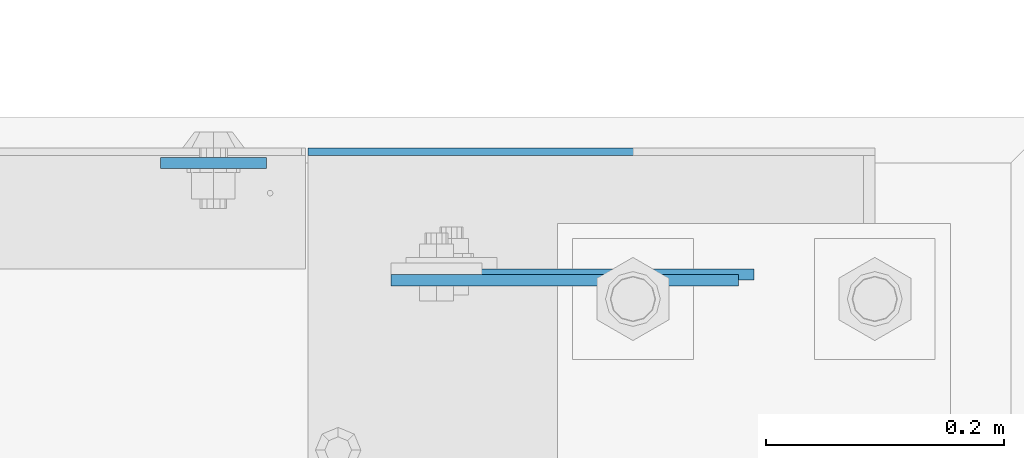
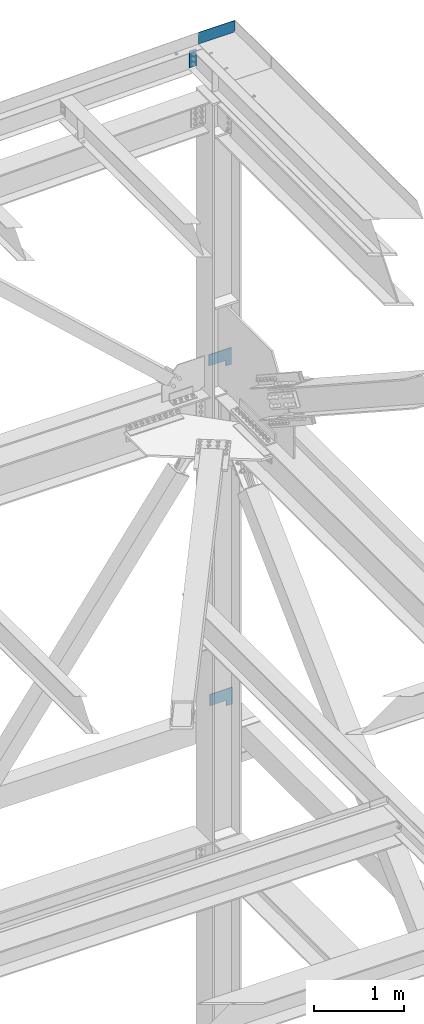
# One storey, part 3659 of 3843: 4 plates, 3 elements without a shape of their own.
"""IFC2X3 building model written with IfcOpenShell, lengths in millimetres."""

from ifc_helpers import new_model, si_unit, frame, origin_with_axes, place, context, subcontext, project, spatial, faceted_brep, material, type_object, element, aggregate, save


model = new_model("IFC2X3")

# Units and contexts
model_context = context("Model", 3, precision=1e-05, world=origin_with_axes())
body_context = subcontext(model_context, "Body", "Model", "MODEL_VIEW")
ifc_project = project(units=[si_unit("LENGTHUNIT", "METRE", prefix="MILLI"), si_unit("AREAUNIT", "SQUARE_METRE"), si_unit("VOLUMEUNIT", "CUBIC_METRE"), si_unit("MASSUNIT", "GRAM", prefix="KILO"), si_unit("TIMEUNIT", "SECOND"), si_unit("PLANEANGLEUNIT", "RADIAN"), si_unit("SOLIDANGLEUNIT", "STERADIAN"), si_unit("THERMODYNAMICTEMPERATUREUNIT", "DEGREE_CELSIUS"), si_unit("LUMINOUSINTENSITYUNIT", "LUMEN")], contexts=[model_context])

# Site, building, storey
site_placement = place(None, origin_with_axes())
site = spatial("IfcSite", under=ifc_project, at=site_placement, CompositionType="ELEMENT")
building_placement = place(site_placement, origin_with_axes())
building = spatial("IfcBuilding", under=site, at=building_placement, Name="Undefined", CompositionType="ELEMENT")
storey_placement = place(building_placement, origin_with_axes())
storey = spatial("IfcBuildingStorey", under=building, at=storey_placement, Name="Undefined", CompositionType="ELEMENT", Elevation=0.0)

# Assembly, plate
assembly_1_placement = place(storey_placement, origin_with_axes())
assembly_1 = element("IfcElementAssembly", 1, at=assembly_1_placement, inside=storey, Name="BEAM", AssemblyPlace="NOTDEFINED", PredefinedType="RIGID_FRAME")
ifc_material = material(Name="STEEL/A572-50")
plate_type_1 = type_object("IfcPlateType", PredefinedType="NOTDEFINED")
plate_1_placement = place(assembly_1_placement, frame((85645.6250000078, 105054.400000026, 46728.6949434642), z_axis=(-1.0, 0.0, 0.0), x_axis=(0.0, 0.0, -1.0)))
plate_1 = element("IfcPlate", 2, at=plate_1_placement, type_object=plate_type_1, material=ifc_material, Name="PLATE", context=body_context, shape_type="Brep", body=[
    faceted_brep([(0.0, -4.76249999999709, 0.0), (0.0, -4.76249999999709, 88.9000015258789), (0.0, 4.76249999999709, 88.9000015258789), (0.0, 4.76249999999709, 0.0), (228.600006102781, -4.7625000004191, 88.9000015257589), (228.600006102781, 4.76249999954598, 88.9000015257443), (228.600006103079, -4.7625000004482, 7.27595761418343e-12), (228.600006103079, 4.76249999954598, -7.27595761418343e-12)], [[[0, 1, 2, 3]], [[1, 4, 5, 2]], [[4, 6, 7, 5]], [[6, 0, 3, 7]], [[5, 7, 3, 2]], [[6, 4, 1, 0]]]),
])

assembly_2_placement = place(storey_placement, origin_with_axes())
assembly_2 = element("IfcElementAssembly", 3, at=assembly_2_placement, inside=storey, Name="GIRT", AssemblyPlace="NOTDEFINED", PredefinedType="RIGID_FRAME")
plate_type_2 = type_object("IfcPlateType", PredefinedType="NOTDEFINED")
plate_2_placement = place(assembly_2_placement, frame((86055.2, 104960.7375, 37744.4), z_axis=(0.0, 0.0, 1.0), x_axis=(-1.0, 0.0, 0.0)))
plate_2 = element("IfcPlate", 4, at=plate_2_placement, type_object=plate_type_2, material=ifc_material, Name="PLATE", context=body_context, shape_type="Brep", body=[
    faceted_brep([(0.0, -4.76249999999709, 0.0), (0.0, -4.76249999999709, 228.599999999999), (0.0, 4.76249999999709, 228.599999999999), (0.0, 4.76249999999709, 0.0), (292.100006103516, -4.76249999999709, 228.600006103516), (292.100006103516, 4.76249999999709, 228.600006103516), (292.100006103516, -4.76249999999709, 76.1999969482422), (292.100006103516, 4.76249999999709, 76.1999969482422), (76.1999893188477, -4.76249999999709, 76.1999969482422), (76.1999893188477, 4.76249999999709, 76.1999969482422), (76.2000000012922, -4.76250000000073, 7.27595761418343e-11), (76.2000000012922, 4.76250000000073, 7.27595761418343e-11)], [[[0, 1, 2, 3]], [[1, 4, 5, 2]], [[4, 6, 7, 5]], [[6, 8, 9, 7]], [[8, 10, 11, 9]], [[10, 0, 3, 11]], [[5, 7, 9, 11, 3, 2]], [[10, 8, 6, 4, 1, 0]]]),
])
aggregate(assembly_2, [plate_2])

assembly_3_placement = place(storey_placement, origin_with_axes())
assembly_3 = element("IfcElementAssembly", 5, at=assembly_3_placement, inside=storey, Name="GIRT", AssemblyPlace="NOTDEFINED", PredefinedType="RIGID_FRAME")
plate_3_placement = place(assembly_3_placement, frame((86042.4999999998, 104955.9745, 42367.2000000001), z_axis=(0.0, 0.0, 1.0), x_axis=(-1.0, 0.0, 0.0)))
plate_3 = element("IfcPlate", 6, at=plate_3_placement, type_object=plate_type_2, material=ifc_material, Name="PLATE", context=body_context, shape_type="Brep", body=[
    faceted_brep([(0.0, -4.76249999999709, 0.0), (0.0, -4.76249999999709, 228.599999999999), (0.0, 4.76249999999709, 228.599999999999), (0.0, 4.76249999999709, 0.0), (292.100006103516, -4.76249999999709, 228.600006103516), (292.100006103516, 4.76249999999709, 228.600006103516), (292.100006103516, -4.76249999999709, 76.1999969482422), (292.100006103516, 4.76249999999709, 76.1999969482422), (76.1999893188477, -4.76249999999709, 76.1999969482422), (76.1999893188477, 4.76249999999709, 76.1999969482422), (76.2000000012922, -4.76250000000073, 7.27595761418343e-11), (76.2000000012922, 4.76250000000073, 7.27595761418343e-11)], [[[0, 1, 2, 3]], [[1, 4, 5, 2]], [[4, 6, 7, 5]], [[6, 8, 9, 7]], [[8, 10, 11, 9]], [[10, 0, 3, 11]], [[5, 7, 9, 11, 3, 2]], [[10, 8, 6, 4, 1, 0]]]),
])
aggregate(assembly_3, [plate_3])

# Plate
plate_type_3 = type_object("IfcPlateType", PredefinedType="NOTDEFINED")
plate_4_placement = place(assembly_1_placement, frame((85680.5500000033, 105063.925, 46777.2750000001), z_axis=(0.0, 0.0, 1.0), x_axis=(1.0, 0.0, 0.0)))
plate_4 = element("IfcPlate", 7, at=plate_4_placement, type_object=plate_type_3, material=ifc_material, Name="PLATE", context=body_context, shape_type="Brep", body=[
    faceted_brep([(0.0, -3.17499999999927, 0.0), (0.0, -3.17499999999927, 155.574999999997), (0.0, 3.17499999999927, 155.574999999997), (0.0, 3.17499999999927, 0.0), (466.724999999991, -3.17499999999927, 155.574999999997), (466.724999999991, 3.17499999999927, 155.574999999997), (466.724999999991, -3.17499999999927, 19.0499992370605), (466.724999999991, 3.17499999999927, 19.0499992370605), (447.675000762931, -3.17499999999927, 0.0), (447.675000762931, 3.17499999999927, 0.0)], [[[0, 1, 2, 3]], [[1, 4, 5, 2]], [[4, 6, 7, 5]], [[6, 8, 9, 7]], [[8, 0, 3, 9]], [[5, 7, 9, 3, 2]], [[8, 6, 4, 1, 0]]]),
])

aggregate(assembly_1, [plate_1, plate_4])

save(model, "model.ifc")
